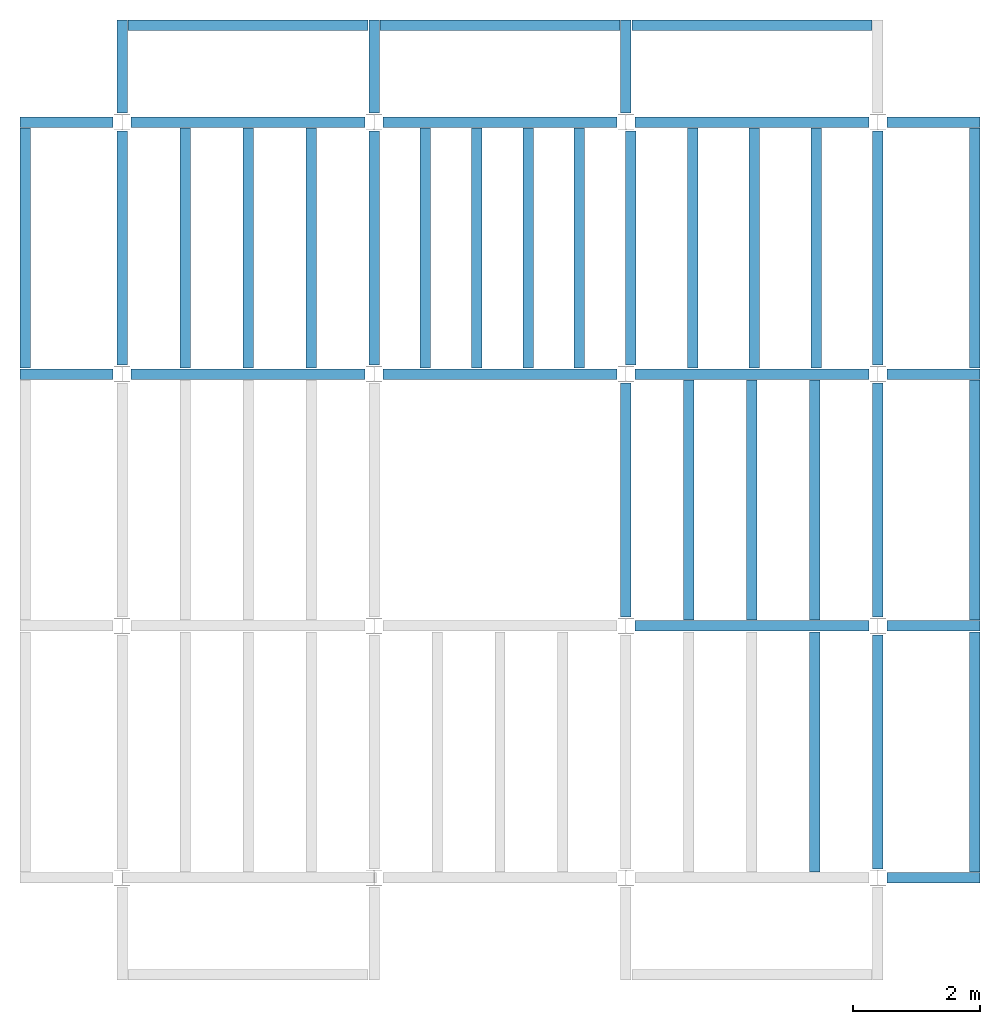
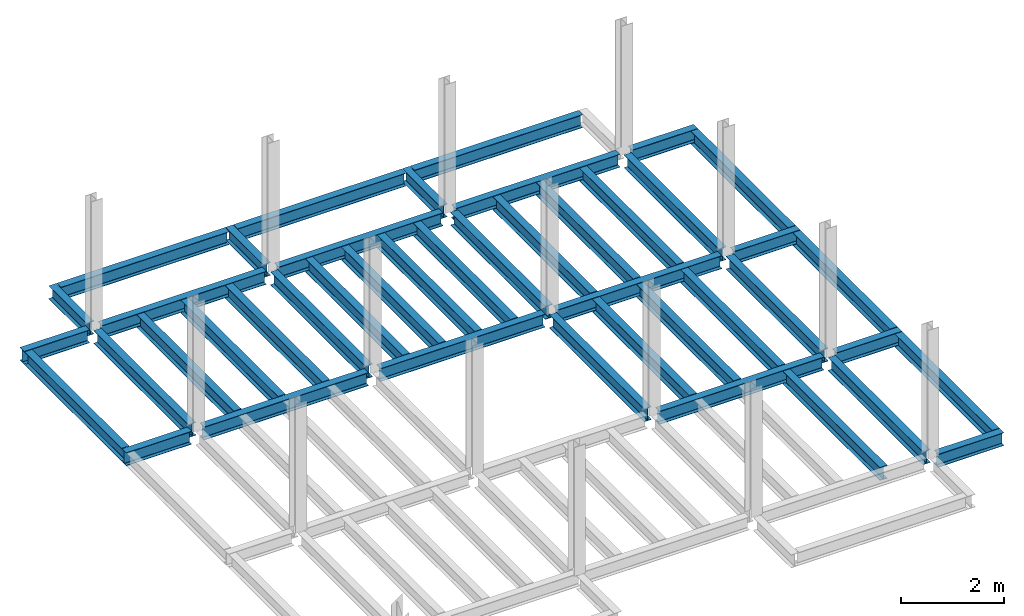
# One storey, part 2 of 3: 44 beams, 5 elements without a shape of their own.
"""IFC4 building model written with IfcOpenShell, lengths in feet."""

from ifc_helpers import new_model, entity, si_unit, converted_unit, derived_unit, direction, frame, origin, place, context, subcontext, project, spatial, line, arc, indexed_curve, outline, extrude, source, transform, mapped, material, type_object, type_shapes, element, aggregate, save


model = new_model("IFC4")

# Units and contexts
model_context = context("Model", 3, precision=0.0001, world=origin(), true_north=direction((6.123233995736766e-17, 1.0)))
plan_context = context("Plan", 3, precision=0.0001, world=origin(), true_north=direction((6.123233995736766e-17, 1.0)))
body_context = subcontext(model_context, "Body", "Model", "MODEL_VIEW")
ifc_project = project(units=[converted_unit("LENGTHUNIT", "FOOT", entity("IfcLengthMeasure", 0.3048), si_unit("LENGTHUNIT", "METRE"), dimensions=[1, 0, 0, 0, 0, 0, 0]), converted_unit("AREAUNIT", "SQUARE FOOT", entity("IfcAreaMeasure", 0.09290304), si_unit("AREAUNIT", "SQUARE_METRE"), dimensions=[2, 0, 0, 0, 0, 0, 0]), converted_unit("PLANEANGLEUNIT", "DEGREE", entity("IfcPlaneAngleMeasure", 0.017453292519943278), si_unit("PLANEANGLEUNIT", "RADIAN"), dimensions=[0, 0, 0, 0, 0, 0, 0]), converted_unit("VOLUMEUNIT", "CUBIC FOOT", entity("IfcVolumeMeasure", 0.028316846592000004), si_unit("VOLUMEUNIT", "CUBIC_METRE"), dimensions=[3, 0, 0, 0, 0, 0, 0]), si_unit("PRESSUREUNIT", "PASCAL"), derived_unit("MASSDENSITYUNIT", [(si_unit("MASSUNIT", "GRAM", prefix="KILO"), 1), (si_unit("LENGTHUNIT", "METRE"), -3)]), derived_unit("VAPORPERMEABILITYUNIT", [(si_unit("LENGTHUNIT", "METRE"), -1), (si_unit("TIMEUNIT", "SECOND"), 1)]), derived_unit("USERDEFINED", [(si_unit("MASSUNIT", "GRAM", prefix="KILO"), 1), (si_unit("LENGTHUNIT", "METRE"), 3), (si_unit("TIMEUNIT", "SECOND"), -3), (si_unit("ELECTRICCURRENTUNIT", "AMPERE"), -2)]), derived_unit("MODULUSOFELASTICITYUNIT", [(si_unit("MASSUNIT", "GRAM", prefix="KILO"), 1), (si_unit("LENGTHUNIT", "METRE"), -1), (si_unit("TIMEUNIT", "SECOND"), -2)]), derived_unit("THERMALEXPANSIONCOEFFICIENTUNIT", [(si_unit("THERMODYNAMICTEMPERATUREUNIT", "KELVIN"), -1)]), derived_unit("SPECIFICHEATCAPACITYUNIT", [(si_unit("TIMEUNIT", "SECOND"), -2), (si_unit("THERMODYNAMICTEMPERATUREUNIT", "KELVIN"), -1), (si_unit("LENGTHUNIT", "METRE"), 2)]), derived_unit("THERMALCONDUCTANCEUNIT", [(si_unit("MASSUNIT", "GRAM", prefix="KILO"), 1), (si_unit("TIMEUNIT", "SECOND"), -3), (si_unit("THERMODYNAMICTEMPERATUREUNIT", "KELVIN"), -1), (si_unit("LENGTHUNIT", "METRE"), 1)])], contexts=[model_context, plan_context])

# Site, building, storey
site_placement = place(None, origin())
site = spatial("IfcSite", under=ifc_project, at=site_placement, CompositionType="ELEMENT")
building_placement = place(site_placement, origin())
building = spatial("IfcBuilding", under=site, at=building_placement, CompositionType="ELEMENT")
storey_placement = place(building_placement, frame((0.0, 0.0, 109.875)))
storey = spatial("IfcBuildingStorey", under=building, at=storey_placement, Name="STR 12", CompositionType="ELEMENT", Elevation=109.875)

# Beams
ifc_material = material(Name="Steel ASTM A992", Category="Metal")
beam_type_1 = type_object("IfcBeamType", Name="W12X26", PredefinedType="JOIST", material=ifc_material)
shared_shape_1 = source(origin(), body_context, "Body", "SweptSolid", [
    extrude(outline(indexed_curve([(-0.27041666666666714, -0.47666666666666574), (-0.27041666666666714, -0.5083333333333351), (0.2704166666666669, -0.5083333333333351), (0.2704166666666669, -0.47666666666666574), (0.03458333333333309, -0.47666666666666574), (0.016905663803669493, -0.46934433619632937), (0.009583333333333202, -0.4516666666666659), (0.0095833333333332, 0.45166666666666705), (0.01690566380366948, 0.4693443361963307), (0.03458333333333325, 0.4766666666666671), (0.2704166666666669, 0.4766666666666671), (0.2704166666666669, 0.5083333333333312), (-0.2704166666666655, 0.5083333333333312), (-0.2704166666666655, 0.4766666666666671), (-0.034583333333333514, 0.47666666666666707), (-0.016905663803669865, 0.46934433619633054), (-0.009583333333333737, 0.45166666666666694), (-0.009583333333333735, -0.4516666666666658), (-0.01690566380367013, -0.4693443361963295), (-0.03458333333333368, -0.47666666666666574)], segments=[line(1, 2, 3, 4, 5), arc(5, 6, 7), line(7, 8), arc(8, 9, 10), line(10, 11, 12, 13, 14, 15), arc(15, 16, 17), line(17, 18), arc(18, 19, 20), line(20, 1)], self_intersect=False)), frame((-6.103346456692914, 0.0, 0.0), z_axis=(-1.0, 0.0, 0.0), x_axis=(0.0, -1.0, 0.0)), (0.0, 0.0, -1.0), 12.083333333333323),
])
type_shapes(beam_type_1, [shared_shape_1])
for number, where, name in (
    (1, (6.561679790026307, 39.0, -0.50833333333334), "W12X26"),
    (2, (6.561679790026288, 26.0, -0.50833333333334), "W12X26"),
):
    element("IfcBeam", number, at=place(storey_placement, frame(where)), inside=storey, type_object=beam_type_1, material=ifc_material, Name=name, ObjectType="W Shapes:W12X26", PredefinedType="JOIST", context=body_context, shape_type="MappedRepresentation", body=[
        mapped(shared_shape_1, transform((0.0, 0.0, 0.0), scale=1.0)),
    ])
beam_1_placement = place(storey_placement, frame((39.0, 6.56167979002612, -0.50833333333334), z_axis=(0.0, 0.0, 1.0), x_axis=(0.0, 1.0, 0.0)))
element("IfcBeam", 3, at=beam_1_placement, inside=storey, type_object=beam_type_1, material=ifc_material, Name="W12X26", ObjectType="W Shapes:W12X26", PredefinedType="JOIST", context=body_context, shape_type="MappedRepresentation", body=[
    mapped(shared_shape_1, transform((0.0, 0.0, 0.0), scale=1.0)),
])
beam_type_2 = type_object("IfcBeamType", Name="W12X26", PredefinedType="JOIST", material=ifc_material)
shared_shape_2 = source(origin(), body_context, "Body", "SweptSolid", [
    extrude(outline(indexed_curve([(-0.27041666666666714, -0.47666666666666574), (-0.27041666666666714, -0.5083333333333351), (0.2704166666666669, -0.5083333333333351), (0.2704166666666669, -0.47666666666666574), (0.03458333333333309, -0.47666666666666574), (0.016905663803669493, -0.46934433619632937), (0.009583333333333202, -0.4516666666666659), (0.0095833333333332, 0.45166666666666705), (0.01690566380366948, 0.4693443361963307), (0.03458333333333325, 0.4766666666666671), (0.2704166666666669, 0.4766666666666671), (0.2704166666666669, 0.5083333333333312), (-0.2704166666666655, 0.5083333333333312), (-0.2704166666666655, 0.4766666666666671), (-0.034583333333333514, 0.47666666666666707), (-0.016905663803669865, 0.46934433619633054), (-0.009583333333333737, 0.45166666666666694), (-0.009583333333333735, -0.4516666666666658), (-0.01690566380367013, -0.4693443361963295), (-0.03458333333333368, -0.47666666666666574)], segments=[line(1, 2, 3, 4, 5), arc(5, 6, 7), line(7, 8), arc(8, 9, 10), line(10, 11, 12, 13, 14, 15), arc(15, 16, 17), line(17, 18), arc(18, 19, 20), line(20, 1)], self_intersect=False)), frame((-6.226706036745409, 0.0, 0.0), z_axis=(-1.0, 0.0, 0.0), x_axis=(0.0, -1.0, 0.0)), (0.0, 0.0, -1.0), 12.08333333333333),
])
type_shapes(beam_type_2, [shared_shape_2])
for number, where, name in (
    (4, (19.685039370078798, 39.0, -0.50833333333334), "W12X26"),
    (5, (19.68503937007878, 26.0, -0.50833333333334), "W12X26"),
):
    element("IfcBeam", number, at=place(storey_placement, frame(where)), inside=storey, type_object=beam_type_2, material=ifc_material, Name=name, ObjectType="W Shapes:W12X26", PredefinedType="JOIST", context=body_context, shape_type="MappedRepresentation", body=[
        mapped(shared_shape_2, transform((0.0, 0.0, 0.0), scale=1.0)),
    ])
for number, where, z_axis, x_axis, name in (
    (6, (39.0, 19.685039370078613, -0.50833333333334), (0.0, 0.0, 1.0), (0.0, 1.0, 0.0), "W12X26"),
    (7, (26.0, 19.685039370078655, -0.50833333333334), (0.0, 0.0, 1.0), (0.0, 1.0, 0.0), "W12X26"),
):
    element("IfcBeam", number, at=place(storey_placement, frame(where, z_axis=z_axis, x_axis=x_axis)), inside=storey, type_object=beam_type_2, material=ifc_material, Name=name, ObjectType="W Shapes:W12X26", PredefinedType="JOIST", context=body_context, shape_type="MappedRepresentation", body=[
        mapped(shared_shape_2, transform((0.0, 0.0, 0.0), scale=1.0)),
    ])

# Assembly, beams
assembly_1_placement = place(storey_placement, origin())
assembly_1 = element("IfcElementAssembly", 8, at=assembly_1_placement, inside=storey, Name="Structural Framing System", ObjectType="Structural Beam System:Structural Framing System", AssemblyPlace="NOTDEFINED", PredefinedType="BEAM_GRID")
beam_type_3 = type_object("IfcBeamType", Name="W12X26", PredefinedType="JOIST", material=ifc_material)
shared_shape_3 = source(origin(), body_context, "Body", "SweptSolid", [
    extrude(outline(indexed_curve([(-0.27041666666666714, -0.47666666666666574), (-0.27041666666666714, -0.5083333333333351), (0.2704166666666669, -0.5083333333333351), (0.2704166666666669, -0.47666666666666574), (0.03458333333333309, -0.47666666666666574), (0.016905663803669493, -0.46934433619632937), (0.009583333333333202, -0.4516666666666659), (0.0095833333333332, 0.45166666666666705), (0.01690566380366948, 0.4693443361963307), (0.03458333333333325, 0.4766666666666671), (0.2704166666666669, 0.4766666666666671), (0.2704166666666669, 0.5083333333333312), (-0.2704166666666655, 0.5083333333333312), (-0.2704166666666655, 0.4766666666666671), (-0.034583333333333514, 0.47666666666666707), (-0.016905663803669865, 0.46934433619633054), (-0.009583333333333737, 0.45166666666666694), (-0.009583333333333735, -0.4516666666666658), (-0.01690566380367013, -0.4693443361963295), (-0.03458333333333368, -0.47666666666666574)], segments=[line(1, 2, 3, 4, 5), arc(5, 6, 7), line(7, 8), arc(8, 9, 10), line(10, 11, 12, 13, 14, 15), arc(15, 16, 17), line(17, 18), arc(18, 19, 20), line(20, 1)], self_intersect=False)), frame((-6.187916666666566, 0.0, 0.0), z_axis=(-1.0, 0.0, 0.0), x_axis=(0.0, -1.0, 0.0)), (0.0, 0.0, -1.0), 12.375833333333075),
])
type_shapes(beam_type_3, [shared_shape_3])
beam_2_placement = place(assembly_1_placement, frame((3.250000000000073, 32.49999999999969, -0.50833333333334), z_axis=(0.0, 0.0, 1.0), x_axis=(0.0, 1.0, 0.0)))
beam_2 = element("IfcBeam", 9, at=beam_2_placement, type_object=beam_type_3, material=ifc_material, Name="W12X26", ObjectType="W Shapes:W12X26", PredefinedType="JOIST", context=body_context, shape_type="MappedRepresentation", body=[
    mapped(shared_shape_3, transform((0.0, 0.0, 0.0), scale=1.0)),
])
beam_3_placement = place(assembly_1_placement, frame((6.500000000000094, 32.49999999999967, -0.50833333333334), z_axis=(0.0, 0.0, 1.0), x_axis=(0.0, 1.0, 0.0)))
beam_3 = element("IfcBeam", 10, at=beam_3_placement, type_object=beam_type_3, material=ifc_material, Name="W12X26", ObjectType="W Shapes:W12X26", PredefinedType="JOIST", context=body_context, shape_type="MappedRepresentation", body=[
    mapped(shared_shape_3, transform((0.0, 0.0, 0.0), scale=1.0)),
])
beam_4_placement = place(assembly_1_placement, frame((9.750000000000115, 32.49999999999966, -0.50833333333334), z_axis=(0.0, 0.0, 1.0), x_axis=(0.0, 1.0, 0.0)))
beam_4 = element("IfcBeam", 11, at=beam_4_placement, type_object=beam_type_3, material=ifc_material, Name="W12X26", ObjectType="W Shapes:W12X26", PredefinedType="JOIST", context=body_context, shape_type="MappedRepresentation", body=[
    mapped(shared_shape_3, transform((0.0, 0.0, 0.0), scale=1.0)),
])
aggregate(assembly_1, [beam_2, beam_3, beam_4])

assembly_2_placement = place(storey_placement, origin())
assembly_2 = element("IfcElementAssembly", 12, at=assembly_2_placement, inside=storey, Name="Structural Framing System", ObjectType="Structural Beam System:Structural Framing System", AssemblyPlace="NOTDEFINED", PredefinedType="BEAM_GRID")
beam_5_placement = place(assembly_2_placement, frame((15.649343832021117, 32.499999999999645, -0.50833333333334), z_axis=(0.0, 0.0, 1.0), x_axis=(0.0, 1.0, 0.0)))
beam_5 = element("IfcBeam", 13, at=beam_5_placement, type_object=beam_type_3, material=ifc_material, Name="W12X26", ObjectType="W Shapes:W12X26", PredefinedType="JOIST", context=body_context, shape_type="MappedRepresentation", body=[
    mapped(shared_shape_3, transform((0.0, 0.0, 0.0), scale=1.0)),
])
beam_6_placement = place(assembly_2_placement, frame((18.2986876640421, 32.49999999999963, -0.50833333333334), z_axis=(0.0, 0.0, 1.0), x_axis=(0.0, 1.0, 0.0)))
beam_6 = element("IfcBeam", 14, at=beam_6_placement, type_object=beam_type_3, material=ifc_material, Name="W12X26", ObjectType="W Shapes:W12X26", PredefinedType="JOIST", context=body_context, shape_type="MappedRepresentation", body=[
    mapped(shared_shape_3, transform((0.0, 0.0, 0.0), scale=1.0)),
])
beam_7_placement = place(assembly_2_placement, frame((20.94803149606308, 32.49999999999963, -0.50833333333334), z_axis=(0.0, 0.0, 1.0), x_axis=(0.0, 1.0, 0.0)))
beam_7 = element("IfcBeam", 15, at=beam_7_placement, type_object=beam_type_3, material=ifc_material, Name="W12X26", ObjectType="W Shapes:W12X26", PredefinedType="JOIST", context=body_context, shape_type="MappedRepresentation", body=[
    mapped(shared_shape_3, transform((0.0, 0.0, 0.0), scale=1.0)),
])

# Assembly, beam
assembly_3_placement = place(storey_placement, origin())
assembly_3 = element("IfcElementAssembly", 16, at=assembly_3_placement, inside=storey, Name="Structural Framing System", ObjectType="Structural Beam System:Structural Framing System", AssemblyPlace="NOTDEFINED", PredefinedType="BEAM_GRID")
beam_8_placement = place(assembly_3_placement, frame((35.7500000000001, 6.499999999999728, -0.50833333333334), z_axis=(0.0, 0.0, 1.0), x_axis=(0.0, 1.0, 0.0)))
beam_8 = element("IfcBeam", 17, at=beam_8_placement, type_object=beam_type_3, material=ifc_material, Name="W12X26", ObjectType="W Shapes:W12X26", PredefinedType="JOIST", context=body_context, shape_type="MappedRepresentation", body=[
    mapped(shared_shape_3, transform((0.0, 0.0, 0.0), scale=1.0)),
])
aggregate(assembly_3, [beam_8])

# Assembly, beams
assembly_4_placement = place(storey_placement, origin())
assembly_4 = element("IfcElementAssembly", 18, at=assembly_4_placement, inside=storey, Name="Structural Framing System", ObjectType="Structural Beam System:Structural Framing System", AssemblyPlace="NOTDEFINED", PredefinedType="BEAM_GRID")
beam_9_placement = place(assembly_4_placement, frame((29.25000000000012, 19.499999999999595, -0.50833333333334), z_axis=(0.0, 0.0, 1.0), x_axis=(0.0, 1.0, 0.0)))
beam_9 = element("IfcBeam", 19, at=beam_9_placement, type_object=beam_type_3, material=ifc_material, Name="W12X26", ObjectType="W Shapes:W12X26", PredefinedType="JOIST", context=body_context, shape_type="MappedRepresentation", body=[
    mapped(shared_shape_3, transform((0.0, 0.0, 0.0), scale=1.0)),
])
beam_10_placement = place(assembly_4_placement, frame((32.500000000000114, 19.49999999999958, -0.50833333333334), z_axis=(0.0, 0.0, 1.0), x_axis=(0.0, 1.0, 0.0)))
beam_10 = element("IfcBeam", 20, at=beam_10_placement, type_object=beam_type_3, material=ifc_material, Name="W12X26", ObjectType="W Shapes:W12X26", PredefinedType="JOIST", context=body_context, shape_type="MappedRepresentation", body=[
    mapped(shared_shape_3, transform((0.0, 0.0, 0.0), scale=1.0)),
])
beam_11_placement = place(assembly_4_placement, frame((35.750000000000114, 19.499999999999574, -0.50833333333334), z_axis=(0.0, 0.0, 1.0), x_axis=(0.0, 1.0, 0.0)))
beam_11 = element("IfcBeam", 21, at=beam_11_placement, type_object=beam_type_3, material=ifc_material, Name="W12X26", ObjectType="W Shapes:W12X26", PredefinedType="JOIST", context=body_context, shape_type="MappedRepresentation", body=[
    mapped(shared_shape_3, transform((0.0, 0.0, 0.0), scale=1.0)),
])
aggregate(assembly_4, [beam_9, beam_10, beam_11])

assembly_5_placement = place(storey_placement, origin())
assembly_5 = element("IfcElementAssembly", 22, at=assembly_5_placement, inside=storey, Name="Structural Framing System", ObjectType="Structural Beam System:Structural Framing System", AssemblyPlace="NOTDEFINED", PredefinedType="BEAM_GRID")
beam_12_placement = place(assembly_5_placement, frame((29.435039370078815, 32.4999999999996, -0.50833333333334), z_axis=(0.0, 0.0, 1.0), x_axis=(0.0, 1.0, 0.0)))
beam_12 = element("IfcBeam", 23, at=beam_12_placement, type_object=beam_type_3, material=ifc_material, Name="W12X26", ObjectType="W Shapes:W12X26", PredefinedType="JOIST", context=body_context, shape_type="MappedRepresentation", body=[
    mapped(shared_shape_3, transform((0.0, 0.0, 0.0), scale=1.0)),
])
beam_13_placement = place(assembly_5_placement, frame((32.62335958005259, 32.49999999999959, -0.50833333333334), z_axis=(0.0, 0.0, 1.0), x_axis=(0.0, 1.0, 0.0)))
beam_13 = element("IfcBeam", 24, at=beam_13_placement, type_object=beam_type_3, material=ifc_material, Name="W12X26", ObjectType="W Shapes:W12X26", PredefinedType="JOIST", context=body_context, shape_type="MappedRepresentation", body=[
    mapped(shared_shape_3, transform((0.0, 0.0, 0.0), scale=1.0)),
])
beam_14_placement = place(assembly_5_placement, frame((35.81167979002636, 32.499999999999574, -0.50833333333334), z_axis=(0.0, 0.0, 1.0), x_axis=(0.0, 1.0, 0.0)))
beam_14 = element("IfcBeam", 25, at=beam_14_placement, type_object=beam_type_3, material=ifc_material, Name="W12X26", ObjectType="W Shapes:W12X26", PredefinedType="JOIST", context=body_context, shape_type="MappedRepresentation", body=[
    mapped(shared_shape_3, transform((0.0, 0.0, 0.0), scale=1.0)),
])
aggregate(assembly_5, [beam_12, beam_13, beam_14])

# Beam
beam_15_placement = place(assembly_2_placement, frame((23.597375328084063, 32.499999999999616, -0.50833333333334), z_axis=(0.0, 0.0, 1.0), x_axis=(0.0, 1.0, 0.0)))
beam_15 = element("IfcBeam", 26, at=beam_15_placement, type_object=beam_type_3, material=ifc_material, Name="W12X26", ObjectType="W Shapes:W12X26", PredefinedType="JOIST", context=body_context, shape_type="MappedRepresentation", body=[
    mapped(shared_shape_3, transform((0.0, 0.0, 0.0), scale=1.0)),
])

aggregate(assembly_2, [beam_5, beam_6, beam_7, beam_15])

# Beams
for number, where, z_axis, x_axis, name in (
    (27, (-5.0, 32.4999999999997, -0.50833333333334), (0.0, 0.0, 1.0), (0.0, 1.0, 0.0), "W12X26"),
    (28, (44.0, 6.4999999999997, -0.50833333333334), (0.0, 0.0, 1.0), (0.0, 1.0, 0.0), "W12X26"),
    (29, (44.0, 19.499999999999545, -0.50833333333334), (0.0, 0.0, 1.0), (0.0, 1.0, 0.0), "W12X26"),
    (30, (44.0, 32.499999999999545, -0.50833333333334), (0.0, 0.0, 1.0), (0.0, 1.0, 0.0), "W12X26"),
):
    element("IfcBeam", number, at=place(storey_placement, frame(where, z_axis=z_axis, x_axis=x_axis)), inside=storey, type_object=beam_type_3, material=ifc_material, Name=name, ObjectType="W Shapes:W12X26", PredefinedType="JOIST", context=body_context, shape_type="MappedRepresentation", body=[
        mapped(shared_shape_3, transform((0.0, 0.0, 0.0), scale=1.0)),
    ])
beam_16_placement = place(storey_placement, frame((6.5000000000001625, 44.0, -0.50833333333334)))
element("IfcBeam", 31, at=beam_16_placement, inside=storey, type_object=beam_type_3, material=ifc_material, Name="W Shapes:W12X26", ObjectType="W Shapes:W12X26", PredefinedType="JOIST", context=body_context, shape_type="MappedRepresentation", body=[
    mapped(shared_shape_3, transform((0.0, 0.0, 0.0), scale=1.0)),
])
beam_type_4 = type_object("IfcBeamType", Name="W12X26", PredefinedType="JOIST", material=ifc_material)
shared_shape_4 = source(origin(), body_context, "Body", "SweptSolid", [
    extrude(outline(indexed_curve([(-0.27041666666666714, -0.47666666666666574), (-0.27041666666666714, -0.5083333333333351), (0.2704166666666669, -0.5083333333333351), (0.2704166666666669, -0.47666666666666574), (0.03458333333333309, -0.47666666666666574), (0.016905663803669493, -0.46934433619632937), (0.009583333333333202, -0.4516666666666659), (0.0095833333333332, 0.45166666666666705), (0.01690566380366948, 0.4693443361963307), (0.03458333333333325, 0.4766666666666671), (0.2704166666666669, 0.4766666666666671), (0.2704166666666669, 0.5083333333333312), (-0.2704166666666655, 0.5083333333333312), (-0.2704166666666655, 0.4766666666666671), (-0.034583333333333514, 0.47666666666666707), (-0.016905663803669865, 0.46934433619633054), (-0.009583333333333737, 0.45166666666666694), (-0.009583333333333735, -0.4516666666666658), (-0.01690566380367013, -0.4693443361963295), (-0.03458333333333368, -0.47666666666666574)], segments=[line(1, 2, 3, 4, 5), arc(5, 6, 7), line(7, 8), arc(8, 9, 10), line(10, 11, 12, 13, 14, 15), arc(15, 16, 17), line(17, 18), arc(18, 19, 20), line(20, 1)], self_intersect=False)), frame((-6.165026246719308, 0.0, 0.0), z_axis=(-1.0, 0.0, 0.0), x_axis=(0.0, -1.0, 0.0)), (0.0, 0.0, -1.0), 12.08333333333334),
])
type_shapes(beam_type_4, [shared_shape_4])
for number, where, name in (
    (32, (32.6233595800526, 39.0, -0.50833333333334), "W12X26"),
    (33, (32.62335958005258, 26.0, -0.50833333333334), "W12X26"),
    (34, (32.62335958005255, 13.0, -0.50833333333334), "W12X26"),
):
    element("IfcBeam", number, at=place(storey_placement, frame(where)), inside=storey, type_object=beam_type_4, material=ifc_material, Name=name, ObjectType="W Shapes:W12X26", PredefinedType="JOIST", context=body_context, shape_type="MappedRepresentation", body=[
        mapped(shared_shape_4, transform((0.0, 0.0, 0.0), scale=1.0)),
    ])
for number, where, z_axis, x_axis, name in (
    (35, (39.0, 32.62335958005221, -0.50833333333334), (0.0, 0.0, 1.0), (0.0, 1.0, 0.0), "W12X26"),
    (36, (26.24671916010504, 32.62335958005225, -0.50833333333334), (0.0, 0.0, 1.0), (0.0, 1.0, 0.0), "W12X26"),
    (37, (13.0, 32.623359580052295, -0.50833333333334), (0.0, 0.0, 1.0), (0.0, 1.0, 0.0), "W12X26"),
    (38, (0.0, 32.62335958005234, -0.50833333333334), (0.0, 0.0, 1.0), (0.0, 1.0, 0.0), "W12X26"),
):
    element("IfcBeam", number, at=place(storey_placement, frame(where, z_axis=z_axis, x_axis=x_axis)), inside=storey, type_object=beam_type_4, material=ifc_material, Name=name, ObjectType="W Shapes:W12X26", PredefinedType="JOIST", context=body_context, shape_type="MappedRepresentation", body=[
        mapped(shared_shape_4, transform((0.0, 0.0, 0.0), scale=1.0)),
    ])
beam_type_5 = type_object("IfcBeamType", Name="W12X26", PredefinedType="JOIST", material=ifc_material)
shared_shape_5 = source(origin(), body_context, "Body", "SweptSolid", [
    extrude(outline(indexed_curve([(0.47666666666666574, -0.2704166666666672), (0.5083333333333351, -0.2704166666666672), (0.5083333333333351, 0.27041666666666686), (0.47666666666666574, 0.27041666666666686), (0.47666666666666574, 0.03458333333333307), (0.46934433619632937, 0.016905663803669473), (0.4516666666666659, 0.00958333333333318), (-0.45166666666666705, 0.00958333333333318), (-0.4693443361963307, 0.01690566380366946), (-0.4766666666666671, 0.03458333333333323), (-0.4766666666666671, 0.27041666666666686), (-0.5083333333333312, 0.27041666666666686), (-0.5083333333333312, -0.27041666666666553), (-0.4766666666666671, -0.27041666666666553), (-0.47666666666666707, -0.034583333333333535), (-0.46934433619633054, -0.016905663803669885), (-0.45166666666666694, -0.00958333333333376), (0.4516666666666658, -0.009583333333333756), (0.4693443361963295, -0.01690566380367015), (0.47666666666666574, -0.0345833333333337)], segments=[line(1, 2, 3, 4, 5), arc(5, 6, 7), line(7, 8), arc(8, 9, 10), line(10, 11, 12, 13, 14, 15), arc(15, 16, 17), line(17, 18), arc(18, 19, 20), line(20, 1)], self_intersect=False)), frame((-2.0416666666666208, 0.0, 0.0), z_axis=(1.0, 0.0, 0.0), x_axis=(0.0, 0.0, -1.0)), (0.0, 0.0, 1.0), 4.812083333333336),
])
type_shapes(beam_type_5, [shared_shape_5])
for number, where, z_axis, x_axis, name in (
    (39, (-2.4999999999998104, 39.0, -0.50833333333334), (0.0, 0.0, 1.0), (-1.0, 0.0, 0.0), "W12X26"),
    (40, (-2.4999999999998317, 26.0, -0.50833333333334), (0.0, 0.0, 1.0), (-1.0, 0.0, 0.0), "W12X26"),
):
    element("IfcBeam", number, at=place(storey_placement, frame(where, z_axis=z_axis, x_axis=x_axis)), inside=storey, type_object=beam_type_5, material=ifc_material, Name=name, ObjectType="W Shapes:W12X26", PredefinedType="JOIST", context=body_context, shape_type="MappedRepresentation", body=[
        mapped(shared_shape_5, transform((0.0, 0.0, 0.0), scale=1.0)),
    ])
beam_type_6 = type_object("IfcBeamType", Name="W12X26", PredefinedType="JOIST", material=ifc_material)
shared_shape_6 = source(origin(), body_context, "Body", "SweptSolid", [
    extrude(outline(indexed_curve([(0.47666666666666574, -0.2704166666666672), (0.5083333333333351, -0.2704166666666672), (0.5083333333333351, 0.27041666666666686), (0.47666666666666574, 0.27041666666666686), (0.47666666666666574, 0.03458333333333307), (0.46934433619632937, 0.016905663803669473), (0.4516666666666659, 0.00958333333333318), (-0.45166666666666705, 0.00958333333333318), (-0.4693443361963307, 0.01690566380366946), (-0.4766666666666671, 0.03458333333333323), (-0.4766666666666671, 0.27041666666666686), (-0.5083333333333312, 0.27041666666666686), (-0.5083333333333312, -0.27041666666666553), (-0.4766666666666671, -0.27041666666666553), (-0.47666666666666707, -0.034583333333333535), (-0.46934433619633054, -0.016905663803669885), (-0.45166666666666694, -0.00958333333333376), (0.4516666666666658, -0.009583333333333756), (0.4693443361963295, -0.01690566380367015), (0.47666666666666574, -0.0345833333333337)], segments=[line(1, 2, 3, 4, 5), arc(5, 6, 7), line(7, 8), arc(8, 9, 10), line(10, 11, 12, 13, 14, 15), arc(15, 16, 17), line(17, 18), arc(18, 19, 20), line(20, 1)], self_intersect=False)), frame((-2.77041666666672, 0.0, 0.0), z_axis=(1.0, 0.0, 0.0), x_axis=(0.0, 0.0, -1.0)), (0.0, 0.0, 1.0), 4.812083333333389),
])
type_shapes(beam_type_6, [shared_shape_6])
for number, where, z_axis, x_axis, name in (
    (41, (41.50000000000013, 26.0, -0.50833333333334), (0.0, 0.0, 1.0), (-1.0, 0.0, 0.0), "W12X26"),
    (42, (41.50000000000011, 13.0, -0.50833333333334), (0.0, 0.0, 1.0), (-1.0, 0.0, 0.0), "W12X26"),
    (43, (41.500000000000085, 0.0, -0.50833333333334), (0.0, 0.0, 1.0), (-1.0, 0.0, 0.0), "W12X26"),
    (44, (13.0, 41.49999999999965, -0.50833333333334), (0.0, 0.0, 1.0), (0.0, -1.0, 0.0), "W12X26"),
    (45, (0.0, 41.499999999999694, -0.50833333333334), (0.0, 0.0, 1.0), (0.0, -1.0, 0.0), "W12X26"),
    (46, (41.50000000000015, 39.0, -0.50833333333334), (0.0, 0.0, 1.0), (-1.0, 0.0, 0.0), "W12X26"),
):
    element("IfcBeam", number, at=place(storey_placement, frame(where, z_axis=z_axis, x_axis=x_axis)), inside=storey, type_object=beam_type_6, material=ifc_material, Name=name, ObjectType="W Shapes:W12X26", PredefinedType="JOIST", context=body_context, shape_type="MappedRepresentation", body=[
        mapped(shared_shape_6, transform((0.0, 0.0, 0.0), scale=1.0)),
    ])
beam_type_7 = type_object("IfcBeamType", Name="W12X26", PredefinedType="JOIST", material=ifc_material)
shared_shape_7 = source(origin(), body_context, "Body", "SweptSolid", [
    extrude(outline(indexed_curve([(0.47666666666666574, -0.2704166666666672), (0.5083333333333351, -0.2704166666666672), (0.5083333333333351, 0.27041666666666686), (0.47666666666666574, 0.27041666666666686), (0.47666666666666574, 0.03458333333333307), (0.46934433619632937, 0.016905663803669473), (0.4516666666666659, 0.00958333333333318), (-0.45166666666666705, 0.00958333333333318), (-0.4693443361963307, 0.01690566380366946), (-0.4766666666666671, 0.03458333333333323), (-0.4766666666666671, 0.27041666666666686), (-0.5083333333333312, 0.27041666666666686), (-0.5083333333333312, -0.27041666666666553), (-0.4766666666666671, -0.27041666666666553), (-0.47666666666666707, -0.034583333333333535), (-0.46934433619633054, -0.016905663803669885), (-0.45166666666666694, -0.00958333333333376), (0.4516666666666658, -0.009583333333333756), (0.4693443361963295, -0.01690566380367015), (0.47666666666666574, -0.0345833333333337)], segments=[line(1, 2, 3, 4, 5), arc(5, 6, 7), line(7, 8), arc(8, 9, 10), line(10, 11, 12, 13, 14, 15), arc(15, 16, 17), line(17, 18), arc(18, 19, 20), line(20, 1)], self_intersect=False)), frame((-6.187916666666685, 0.0, 0.0), z_axis=(1.0, 0.0, 0.0), x_axis=(0.0, 0.0, -1.0)), (0.0, 0.0, 1.0), 12.375833333333318),
])
type_shapes(beam_type_7, [shared_shape_7])
beam_17_placement = place(storey_placement, frame((19.500000000000142, 44.0, -0.50833333333334), z_axis=(0.0, 0.0, 1.0), x_axis=(-1.0, 0.0, 0.0)))
element("IfcBeam", 47, at=beam_17_placement, inside=storey, type_object=beam_type_7, material=ifc_material, Name="W Shapes:W12X26", ObjectType="W Shapes:W12X26", PredefinedType="JOIST", context=body_context, shape_type="MappedRepresentation", body=[
    mapped(shared_shape_7, transform((0.0, 0.0, 0.0), scale=1.0)),
])
beam_type_8 = type_object("IfcBeamType", Name="W12X26", PredefinedType="JOIST", material=ifc_material)
shared_shape_8 = source(origin(), body_context, "Body", "SweptSolid", [
    extrude(outline(indexed_curve([(-0.2704166666666694, -0.50833333333334), (0.27041666666666586, -0.50833333333334), (0.2704166666666623, -0.4766666666666737), (0.034583333333333854, -0.4766666666666879), (0.016905663803669313, -0.4693443361963432), (0.009583333333335275, -0.4516666666666822), (0.009583333333335275, 0.4516666666666538), (0.016905663803669313, 0.46934433619631477), (0.034583333333333854, 0.47666666666665947), (0.2704166666666694, 0.47666666666665947), (0.27041666666666586, 0.5083333333333258), (-0.27041666666666586, 0.5083333333333258), (-0.27041666666666586, 0.47666666666665947), (-0.0345833333333303, 0.47666666666665947), (-0.01690566380366576, 0.46934433619631477), (-0.009583333333331723, 0.4516666666666538), (-0.009583333333331723, -0.4516666666666822), (-0.01690566380366576, -0.4693443361963432), (-0.034583333333333854, -0.4766666666666737), (-0.27041666666666586, -0.4766666666666737)], segments=[line(1, 2, 3, 4), arc(4, 5, 6), line(6, 7), arc(7, 8, 9), line(9, 10, 11, 12, 13, 14), arc(14, 15, 16), line(16, 17), arc(17, 18, 19), line(19, 20, 1)], self_intersect=False)), frame((26.0, 44.27041666666632, 109.36666666666663), z_axis=(0.0, -1.0, 0.0), x_axis=(-1.0, 0.0, 0.0)), (0.0, 0.0, 1.0), 4.812083333333393),
])
type_shapes(beam_type_8, [shared_shape_8])
beam_18_placement = place(storey_placement, frame((0.0, 0.0, -109.875)))
element("IfcBeam", 48, at=beam_18_placement, inside=storey, type_object=beam_type_8, material=ifc_material, Name="W12X26", ObjectType="W Shapes:W12X26", PredefinedType="JOIST", context=body_context, shape_type="MappedRepresentation", body=[
    mapped(shared_shape_8, transform((0.0, 0.0, 0.0), scale=1.0)),
])
beam_type_9 = type_object("IfcBeamType", Name="W12X26", PredefinedType="JOIST", material=ifc_material)
shared_shape_9 = source(origin(), body_context, "Body", "SweptSolid", [
    extrude(outline(indexed_curve([(-0.5083333333333258, -0.2704166666666694), (-0.47666666666665947, -0.2704166666666694), (-0.4766666666666737, -0.03458333333333741), (-0.469344336196329, -0.01690566380367642), (-0.451666666666668, -0.009583333333338828), (0.451666666666668, -0.009583333333338828), (0.469344336196329, -0.01690566380367642), (0.4766666666666737, -0.03458333333333741), (0.4766666666666737, -0.2704166666666694), (0.50833333333334, -0.2704166666666694), (0.50833333333334, 0.2704166666666623), (0.4766666666666737, 0.2704166666666623), (0.4766666666666737, 0.0345833333333303), (0.469344336196329, 0.016905663803669313), (0.451666666666668, 0.009583333333331723), (-0.451666666666668, 0.009583333333331723), (-0.469344336196329, 0.016905663803669313), (-0.47666666666665947, 0.0345833333333303), (-0.47666666666665947, 0.2704166666666623), (-0.5083333333333258, 0.2704166666666623)], segments=[line(1, 2, 3), arc(3, 4, 5), line(5, 6), arc(6, 7, 8), line(8, 9, 10, 11, 12, 13), arc(13, 14, 15), line(15, 16), arc(16, 17, 18), line(18, 19, 20, 1)], self_intersect=False)), frame((26.312083333333604, 44.0, 109.36666666666665), z_axis=(1.0, 0.0, 0.0), x_axis=(0.0, 0.0, -1.0)), (0.0, 0.0, 1.0), 12.375833333333079),
])
type_shapes(beam_type_9, [shared_shape_9])
beam_19_placement = place(storey_placement, frame((0.0, 0.0, -109.875)))
element("IfcBeam", 49, at=beam_19_placement, inside=storey, type_object=beam_type_9, material=ifc_material, Name="W Shapes:W12X26", ObjectType="W Shapes:W12X26", PredefinedType="JOIST", context=body_context, shape_type="MappedRepresentation", body=[
    mapped(shared_shape_9, transform((0.0, 0.0, 0.0), scale=1.0)),
])

save(model, "model.ifc")
